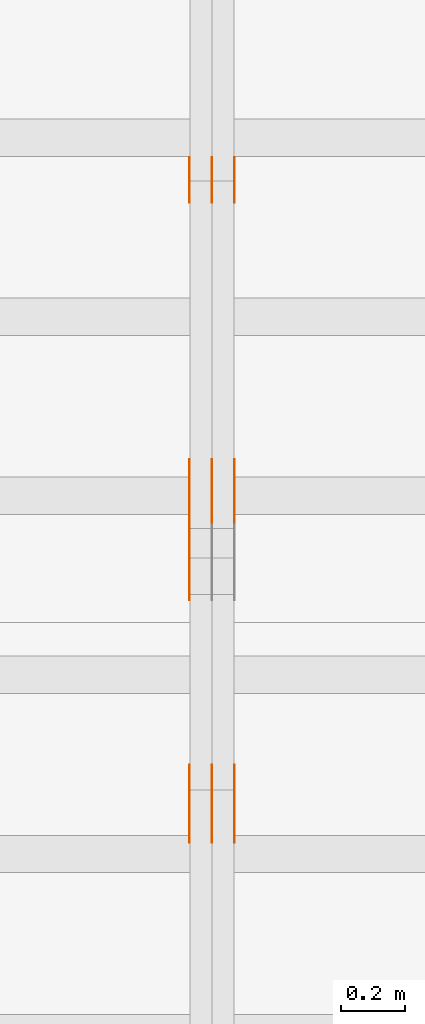
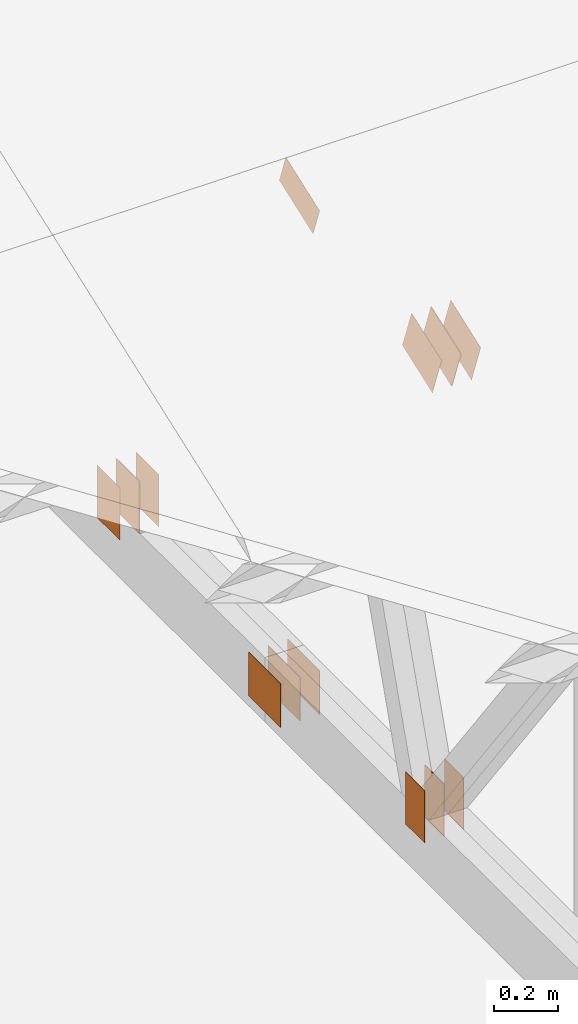
# One storey, part 75 of 189: 17 proxies.
"""IFC2X3 building model written with IfcOpenShell, lengths in millimetres."""

from ifc_helpers import new_model, entity, si_unit, converted_unit, derived_unit, direction, frame, frame_2d, origin, origin_2d_with_axis, place, context, subcontext, project, spatial, polyline, rectangle, outline, extrude, source, transform, mapped, material, type_object, type_shapes, element, save


model = new_model("IFC2X3")

# Units and contexts
model_context = context("Model", 3, precision=0.01, world=origin(), true_north=direction((6.12303176911189e-17, 1.0)))
body_context = subcontext(model_context, "Body", "Model", "MODEL_VIEW")
ifc_project = project(units=[si_unit("LENGTHUNIT", "METRE", prefix="MILLI"), si_unit("AREAUNIT", "SQUARE_METRE"), si_unit("VOLUMEUNIT", "CUBIC_METRE"), converted_unit("PLANEANGLEUNIT", "DEGREE", entity("IfcRatioMeasure", 0.0174532925199433), si_unit("PLANEANGLEUNIT", "RADIAN"), dimensions=[0, 0, 0, 0, 0, 0, 0]), si_unit("MASSUNIT", "GRAM", prefix="KILO"), derived_unit("MASSDENSITYUNIT", [(si_unit("MASSUNIT", "GRAM", prefix="KILO"), 1), (si_unit("LENGTHUNIT", "METRE"), -3)]), si_unit("TIMEUNIT", "SECOND"), si_unit("FREQUENCYUNIT", "HERTZ"), si_unit("THERMODYNAMICTEMPERATUREUNIT", "DEGREE_CELSIUS"), derived_unit("THERMALTRANSMITTANCEUNIT", [(si_unit("MASSUNIT", "GRAM", prefix="KILO"), 1), (si_unit("THERMODYNAMICTEMPERATUREUNIT", "KELVIN"), -1), (si_unit("TIMEUNIT", "SECOND"), -3)]), derived_unit("VOLUMETRICFLOWRATEUNIT", [(si_unit("LENGTHUNIT", "METRE"), 3), (si_unit("TIMEUNIT", "SECOND"), -1)]), si_unit("ELECTRICCURRENTUNIT", "AMPERE"), si_unit("ELECTRICVOLTAGEUNIT", "VOLT"), si_unit("POWERUNIT", "WATT"), si_unit("FORCEUNIT", "NEWTON"), si_unit("ILLUMINANCEUNIT", "LUX"), si_unit("LUMINOUSFLUXUNIT", "LUMEN"), si_unit("LUMINOUSINTENSITYUNIT", "CANDELA"), derived_unit("USERDEFINED", [(si_unit("MASSUNIT", "GRAM", prefix="KILO"), -1), (si_unit("LENGTHUNIT", "METRE"), -2), (si_unit("TIMEUNIT", "SECOND"), 3), (si_unit("LUMINOUSFLUXUNIT", "LUMEN"), 1)]), derived_unit("LINEARVELOCITYUNIT", [(si_unit("LENGTHUNIT", "METRE"), 1), (si_unit("TIMEUNIT", "SECOND"), -1)]), si_unit("PRESSUREUNIT", "PASCAL"), derived_unit("USERDEFINED", [(si_unit("LENGTHUNIT", "METRE"), -2), (si_unit("MASSUNIT", "GRAM", prefix="KILO"), 1), (si_unit("TIMEUNIT", "SECOND"), -2)])], contexts=[model_context])

# Site, building, storey
site_placement = place(None, origin())
site = spatial("IfcSite", under=ifc_project, at=site_placement, CompositionType="ELEMENT")
building_placement = place(site_placement, origin())
building = spatial("IfcBuilding", under=site, at=building_placement, CompositionType="ELEMENT")
storey_placement = place(building_placement, origin())
storey = spatial("IfcBuildingStorey", under=building, at=storey_placement, Name="Default", CompositionType="ELEMENT", Elevation=0.0)

# Proxies
ifc_material_1 = material(Name="IfcSurfaceStyle #79002")
building_element_proxy_type_1 = type_object("IfcBuildingElementProxyType", PredefinedType="NOTDEFINED", material=ifc_material_1)
shared_shape_1 = source(origin(), body_context, "Body", "SweptSolid", [
    extrude(rectangle(XDim=200.0, YDim=144.0, at=frame_2d((1.4210854715202e-14, 0.0), x_axis=(1.0, 0.0))), frame((100.0, 72.0, 0.0), z_axis=(0.0, 0.0, 1.0), x_axis=(-1.0, 0.0, 0.0)), (0.0, 0.0, 1.0), 1.3),
])
type_shapes(building_element_proxy_type_1, [shared_shape_1])
proxy_1_placement = place(building_placement, frame((12301.3, 6668.833984375, 145.0), z_axis=(-1.0, 0.0, 0.0), x_axis=(0.0, 0.0, 1.0)))
element("IfcBuildingElementProxy", 1, at=proxy_1_placement, inside=storey, type_object=building_element_proxy_type_1, material=ifc_material_1, context=body_context, shape_type="MappedRepresentation", body=[
    mapped(shared_shape_1, transform((0.0, 0.0, 0.0), scale=1.0)),
])
ifc_material_2 = material(Name="IfcSurfaceStyle #78945")
building_element_proxy_type_2 = type_object("IfcBuildingElementProxyType", PredefinedType="NOTDEFINED", material=ifc_material_2)
shared_shape_2 = source(origin(), body_context, "Body", "SweptSolid", [
    extrude(rectangle(XDim=200.0, YDim=144.0, at=frame_2d((1.4210854715202e-14, 0.0), x_axis=(1.0, 0.0))), frame((100.0, 72.0, 0.0), z_axis=(0.0, 0.0, 1.0), x_axis=(-1.0, 0.0, 0.0)), (0.0, 0.0, 1.0), 1.29999999999998),
])
type_shapes(building_element_proxy_type_2, [shared_shape_2])
proxy_2_placement = place(building_placement, frame((12230.0, 6668.833984375, 145.0), z_axis=(-1.0, 0.0, 0.0), x_axis=(0.0, 0.0, 1.0)))
element("IfcBuildingElementProxy", 2, at=proxy_2_placement, inside=storey, type_object=building_element_proxy_type_2, material=ifc_material_2, context=body_context, shape_type="MappedRepresentation", body=[
    mapped(shared_shape_2, transform((0.0, 0.0, 0.0), scale=1.0)),
])
ifc_material_3 = material(Name="IfcSurfaceStyle #78888")
building_element_proxy_type_3 = type_object("IfcBuildingElementProxyType", PredefinedType="NOTDEFINED", material=ifc_material_3)
shared_shape_3 = source(origin(), body_context, "Body", "SweptSolid", [
    extrude(rectangle(XDim=200.0, YDim=144.0, at=frame_2d((1.4210854715202e-14, 0.0), x_axis=(1.0, 0.0))), frame((100.0, 72.0, 0.0), z_axis=(0.0, 0.0, 1.0), x_axis=(-1.0, 0.0, 0.0)), (0.0, 0.0, 1.0), 1.29999999999998),
])
type_shapes(building_element_proxy_type_3, [shared_shape_3])
proxy_3_placement = place(building_placement, frame((12231.3, 6668.833984375, 145.0), z_axis=(-1.0, 0.0, 0.0), x_axis=(0.0, 0.0, 1.0)))
element("IfcBuildingElementProxy", 3, at=proxy_3_placement, inside=storey, type_object=building_element_proxy_type_3, material=ifc_material_3, context=body_context, shape_type="MappedRepresentation", body=[
    mapped(shared_shape_3, transform((0.0, 0.0, 0.0), scale=1.0)),
])
ifc_material_4 = material(Name="IfcSurfaceStyle #78831")
building_element_proxy_type_4 = type_object("IfcBuildingElementProxyType", PredefinedType="NOTDEFINED", material=ifc_material_4)
shared_shape_4 = source(origin(), body_context, "Body", "SweptSolid", [
    extrude(rectangle(XDim=200.0, YDim=144.0, at=frame_2d((1.4210854715202e-14, 0.0), x_axis=(1.0, 0.0))), frame((100.0, 72.0, 0.0), z_axis=(0.0, 0.0, 1.0), x_axis=(-1.0, 0.0, 0.0)), (0.0, 0.0, 1.0), 1.29999999999999),
])
type_shapes(building_element_proxy_type_4, [shared_shape_4])
proxy_4_placement = place(building_placement, frame((12160.0, 6668.833984375, 145.0), z_axis=(-1.0, 0.0, 0.0), x_axis=(0.0, 0.0, 1.0)))
element("IfcBuildingElementProxy", 4, at=proxy_4_placement, inside=storey, type_object=building_element_proxy_type_4, material=ifc_material_4, context=body_context, shape_type="MappedRepresentation", body=[
    mapped(shared_shape_4, transform((0.0, 0.0, 0.0), scale=1.0)),
])
ifc_material_5 = material(Name="IfcSurfaceStyle #78774")
building_element_proxy_type_5 = type_object("IfcBuildingElementProxyType", PredefinedType="NOTDEFINED", material=ifc_material_5)
shared_shape_5 = source(origin(), body_context, "Body", "SweptSolid", [
    extrude(rectangle(XDim=200.0, YDim=168.0, at=origin_2d_with_axis()), frame((100.0, 84.0, 0.0), z_axis=(0.0, 0.0, 1.0), x_axis=(-1.0, 0.0, 0.0)), (0.0, 0.0, 1.0), 1.3),
])
type_shapes(building_element_proxy_type_5, [shared_shape_5])
proxy_5_placement = place(building_placement, frame((12301.3, 5662.466796875, 206.5), z_axis=(-1.0, 0.0, 0.0), x_axis=(0.0, 1.0, 0.0)))
element("IfcBuildingElementProxy", 5, at=proxy_5_placement, inside=storey, type_object=building_element_proxy_type_5, material=ifc_material_5, context=body_context, shape_type="MappedRepresentation", body=[
    mapped(shared_shape_5, transform((0.0, 0.0, 0.0), scale=1.0)),
])
ifc_material_6 = material(Name="IfcSurfaceStyle #78717")
building_element_proxy_type_6 = type_object("IfcBuildingElementProxyType", PredefinedType="NOTDEFINED", material=ifc_material_6)
shared_shape_6 = source(origin(), body_context, "Body", "SweptSolid", [
    extrude(rectangle(XDim=200.0, YDim=168.0, at=origin_2d_with_axis()), frame((100.0, 84.0, 0.0), z_axis=(0.0, 0.0, 1.0), x_axis=(-1.0, 0.0, 0.0)), (0.0, 0.0, 1.0), 1.29999999999998),
])
type_shapes(building_element_proxy_type_6, [shared_shape_6])
proxy_6_placement = place(building_placement, frame((12230.0, 5662.466796875, 206.5), z_axis=(-1.0, 0.0, 0.0), x_axis=(0.0, 1.0, 0.0)))
element("IfcBuildingElementProxy", 6, at=proxy_6_placement, inside=storey, type_object=building_element_proxy_type_6, material=ifc_material_6, context=body_context, shape_type="MappedRepresentation", body=[
    mapped(shared_shape_6, transform((0.0, 0.0, 0.0), scale=1.0)),
])
ifc_material_7 = material(Name="IfcSurfaceStyle #78660")
building_element_proxy_type_7 = type_object("IfcBuildingElementProxyType", PredefinedType="NOTDEFINED", material=ifc_material_7)
shared_shape_7 = source(origin(), body_context, "Body", "SweptSolid", [
    extrude(rectangle(XDim=200.0, YDim=168.0, at=origin_2d_with_axis()), frame((100.0, 84.0, 0.0), z_axis=(0.0, 0.0, 1.0), x_axis=(-1.0, 0.0, 0.0)), (0.0, 0.0, 1.0), 1.29999999999998),
])
type_shapes(building_element_proxy_type_7, [shared_shape_7])
proxy_7_placement = place(building_placement, frame((12231.3, 5662.466796875, 206.5), z_axis=(-1.0, 0.0, 0.0), x_axis=(0.0, 1.0, 0.0)))
element("IfcBuildingElementProxy", 7, at=proxy_7_placement, inside=storey, type_object=building_element_proxy_type_7, material=ifc_material_7, context=body_context, shape_type="MappedRepresentation", body=[
    mapped(shared_shape_7, transform((0.0, 0.0, 0.0), scale=1.0)),
])
ifc_material_8 = material(Name="IfcSurfaceStyle #78603")
building_element_proxy_type_8 = type_object("IfcBuildingElementProxyType", PredefinedType="NOTDEFINED", material=ifc_material_8)
shared_shape_8 = source(origin(), body_context, "Body", "SweptSolid", [
    extrude(rectangle(XDim=200.0, YDim=168.0, at=origin_2d_with_axis()), frame((100.0, 84.0, 0.0), z_axis=(0.0, 0.0, 1.0), x_axis=(-1.0, 0.0, 0.0)), (0.0, 0.0, 1.0), 1.29999999999999),
])
type_shapes(building_element_proxy_type_8, [shared_shape_8])
proxy_8_placement = place(building_placement, frame((12160.0, 5662.466796875, 206.5), z_axis=(-1.0, 0.0, 0.0), x_axis=(0.0, 1.0, 0.0)))
element("IfcBuildingElementProxy", 8, at=proxy_8_placement, inside=storey, type_object=building_element_proxy_type_8, material=ifc_material_8, context=body_context, shape_type="MappedRepresentation", body=[
    mapped(shared_shape_8, transform((0.0, 0.0, 0.0), scale=1.0)),
])
ifc_material_9 = material(Name="IfcSurfaceStyle #74955")
building_element_proxy_type_9 = type_object("IfcBuildingElementProxyType", PredefinedType="NOTDEFINED", material=ifc_material_9)
shared_shape_9 = source(origin(), body_context, "Body", "SweptSolid", [
    extrude(outline(polyline([(-112.500654374667, -59.9999021691247), (112.500117969231, -59.9999021691247), (112.500612624162, 59.9999021691247), (-112.500076218726, 59.9999021691247), (-112.500654374667, -59.9999021691247)])), frame((112.500612624162, 60.0003514046321, 0.0), z_axis=(0.0, 0.0, 1.0), x_axis=(-1.0, 0.0, 0.0)), (0.0, 0.0, 1.0), 1.29999999999999),
])
type_shapes(building_element_proxy_type_9, [shared_shape_9])
proxy_9_placement = place(building_placement, frame((12160.0, 5418.0703125, 2162.37353515625), z_axis=(-1.0, 0.0, 0.0), x_axis=(0.0, 0.939692620785908, 0.342020143325669)))
element("IfcBuildingElementProxy", 9, at=proxy_9_placement, inside=storey, type_object=building_element_proxy_type_9, material=ifc_material_9, context=body_context, shape_type="MappedRepresentation", body=[
    mapped(shared_shape_9, transform((0.0, 0.0, 0.0), scale=1.0)),
])
ifc_material_10 = material(Name="IfcSurfaceStyle #74442")
building_element_proxy_type_10 = type_object("IfcBuildingElementProxyType", PredefinedType="NOTDEFINED", material=ifc_material_10)
shared_shape_10 = source(origin(), body_context, "Body", "SweptSolid", [
    extrude(rectangle(XDim=200.0, YDim=120.0, at=origin_2d_with_axis()), frame((100.0, 60.0, 0.0), z_axis=(0.0, 0.0, 1.0), x_axis=(-1.0, 0.0, 0.0)), (0.0, 0.0, 1.0), 1.3),
])
type_shapes(building_element_proxy_type_10, [shared_shape_10])
proxy_10_placement = place(building_placement, frame((12301.3, 4760.65625, 145.0), z_axis=(-1.0, 0.0, 0.0), x_axis=(0.0, 0.0, 1.0)))
element("IfcBuildingElementProxy", 10, at=proxy_10_placement, inside=storey, type_object=building_element_proxy_type_10, material=ifc_material_10, context=body_context, shape_type="MappedRepresentation", body=[
    mapped(shared_shape_10, transform((0.0, 0.0, 0.0), scale=1.0)),
])
ifc_material_11 = material(Name="IfcSurfaceStyle #74385")
building_element_proxy_type_11 = type_object("IfcBuildingElementProxyType", PredefinedType="NOTDEFINED", material=ifc_material_11)
shared_shape_11 = source(origin(), body_context, "Body", "SweptSolid", [
    extrude(rectangle(XDim=200.0, YDim=120.0, at=origin_2d_with_axis()), frame((100.0, 60.0, 0.0), z_axis=(0.0, 0.0, 1.0), x_axis=(-1.0, 0.0, 0.0)), (0.0, 0.0, 1.0), 1.29999999999998),
])
type_shapes(building_element_proxy_type_11, [shared_shape_11])
proxy_11_placement = place(building_placement, frame((12230.0, 4760.65625, 145.0), z_axis=(-1.0, 0.0, 0.0), x_axis=(0.0, 0.0, 1.0)))
element("IfcBuildingElementProxy", 11, at=proxy_11_placement, inside=storey, type_object=building_element_proxy_type_11, material=ifc_material_11, context=body_context, shape_type="MappedRepresentation", body=[
    mapped(shared_shape_11, transform((0.0, 0.0, 0.0), scale=1.0)),
])
ifc_material_12 = material(Name="IfcSurfaceStyle #74328")
building_element_proxy_type_12 = type_object("IfcBuildingElementProxyType", PredefinedType="NOTDEFINED", material=ifc_material_12)
shared_shape_12 = source(origin(), body_context, "Body", "SweptSolid", [
    extrude(rectangle(XDim=200.0, YDim=120.0, at=origin_2d_with_axis()), frame((100.0, 60.0, 0.0), z_axis=(0.0, 0.0, 1.0), x_axis=(-1.0, 0.0, 0.0)), (0.0, 0.0, 1.0), 1.29999999999998),
])
type_shapes(building_element_proxy_type_12, [shared_shape_12])
proxy_12_placement = place(building_placement, frame((12231.3, 4760.65625, 145.0), z_axis=(-1.0, 0.0, 0.0), x_axis=(0.0, 0.0, 1.0)))
element("IfcBuildingElementProxy", 12, at=proxy_12_placement, inside=storey, type_object=building_element_proxy_type_12, material=ifc_material_12, context=body_context, shape_type="MappedRepresentation", body=[
    mapped(shared_shape_12, transform((0.0, 0.0, 0.0), scale=1.0)),
])
ifc_material_13 = material(Name="IfcSurfaceStyle #74271")
building_element_proxy_type_13 = type_object("IfcBuildingElementProxyType", PredefinedType="NOTDEFINED", material=ifc_material_13)
shared_shape_13 = source(origin(), body_context, "Body", "SweptSolid", [
    extrude(rectangle(XDim=200.0, YDim=120.0, at=origin_2d_with_axis()), frame((100.0, 60.0, 0.0), z_axis=(0.0, 0.0, 1.0), x_axis=(-1.0, 0.0, 0.0)), (0.0, 0.0, 1.0), 1.29999999999999),
])
type_shapes(building_element_proxy_type_13, [shared_shape_13])
proxy_13_placement = place(building_placement, frame((12160.0, 4760.65625, 145.0), z_axis=(-1.0, 0.0, 0.0), x_axis=(0.0, 0.0, 1.0)))
element("IfcBuildingElementProxy", 13, at=proxy_13_placement, inside=storey, type_object=building_element_proxy_type_13, material=ifc_material_13, context=body_context, shape_type="MappedRepresentation", body=[
    mapped(shared_shape_13, transform((0.0, 0.0, 0.0), scale=1.0)),
])
ifc_material_14 = material(Name="IfcSurfaceStyle #69546")
building_element_proxy_type_14 = type_object("IfcBuildingElementProxyType", PredefinedType="NOTDEFINED", material=ifc_material_14)
shared_shape_14 = source(origin(), body_context, "Body", "SweptSolid", [
    extrude(outline(polyline([(-99.9993269270171, -84.0000832532405), (99.9997189122032, -84.0000832532405), (99.9992851765118, 84.0000832532405), (-99.999677161698, 84.0000832532405), (-99.9993269270171, -84.0000832532405)])), frame((99.9999283659736, 84.0000832532405, 0.0), z_axis=(0.0, 0.0, 1.0), x_axis=(-1.0, 0.0, 0.0)), (0.0, 0.0, 1.0), 1.3),
])
type_shapes(building_element_proxy_type_14, [shared_shape_14])
proxy_14_placement = place(building_placement, frame((12301.3, 4654.06379965055, 2052.96988554922), z_axis=(-1.0, 0.0, 0.0), x_axis=(0.0, 0.939692620785908, 0.342020143325669)))
element("IfcBuildingElementProxy", 14, at=proxy_14_placement, inside=storey, type_object=building_element_proxy_type_14, material=ifc_material_14, context=body_context, shape_type="MappedRepresentation", body=[
    mapped(shared_shape_14, transform((0.0, 0.0, 0.0), scale=1.0)),
])
ifc_material_15 = material(Name="IfcSurfaceStyle #69489")
building_element_proxy_type_15 = type_object("IfcBuildingElementProxyType", PredefinedType="NOTDEFINED", material=ifc_material_15)
shared_shape_15 = source(origin(), body_context, "Body", "SweptSolid", [
    extrude(outline(polyline([(-99.9993269270171, -84.0000832532405), (99.9997189122032, -84.0000832532405), (99.9992851765118, 84.0000832532405), (-99.999677161698, 84.0000832532405), (-99.9993269270171, -84.0000832532405)])), frame((99.9999283659736, 84.0000832532405, 0.0), z_axis=(0.0, 0.0, 1.0), x_axis=(-1.0, 0.0, 0.0)), (0.0, 0.0, 1.0), 1.29999999999998),
])
type_shapes(building_element_proxy_type_15, [shared_shape_15])
proxy_15_placement = place(building_placement, frame((12230.0, 4654.06379965055, 2052.96988554922), z_axis=(-1.0, 0.0, 0.0), x_axis=(0.0, 0.939692620785908, 0.342020143325669)))
element("IfcBuildingElementProxy", 15, at=proxy_15_placement, inside=storey, type_object=building_element_proxy_type_15, material=ifc_material_15, context=body_context, shape_type="MappedRepresentation", body=[
    mapped(shared_shape_15, transform((0.0, 0.0, 0.0), scale=1.0)),
])
ifc_material_16 = material(Name="IfcSurfaceStyle #69432")
building_element_proxy_type_16 = type_object("IfcBuildingElementProxyType", PredefinedType="NOTDEFINED", material=ifc_material_16)
shared_shape_16 = source(origin(), body_context, "Body", "SweptSolid", [
    extrude(outline(polyline([(-99.9993269270171, -84.0000832532405), (99.9997189122032, -84.0000832532405), (99.9992851765118, 84.0000832532405), (-99.999677161698, 84.0000832532405), (-99.9993269270171, -84.0000832532405)])), frame((99.9999283659736, 84.0000832532405, 0.0), z_axis=(0.0, 0.0, 1.0), x_axis=(-1.0, 0.0, 0.0)), (0.0, 0.0, 1.0), 1.29999999999998),
])
type_shapes(building_element_proxy_type_16, [shared_shape_16])
proxy_16_placement = place(building_placement, frame((12231.3, 4654.06379965055, 2052.96988554922), z_axis=(-1.0, 0.0, 0.0), x_axis=(0.0, 0.939692620785908, 0.342020143325669)))
element("IfcBuildingElementProxy", 16, at=proxy_16_placement, inside=storey, type_object=building_element_proxy_type_16, material=ifc_material_16, context=body_context, shape_type="MappedRepresentation", body=[
    mapped(shared_shape_16, transform((0.0, 0.0, 0.0), scale=1.0)),
])
ifc_material_17 = material(Name="IfcSurfaceStyle #69375")
building_element_proxy_type_17 = type_object("IfcBuildingElementProxyType", PredefinedType="NOTDEFINED", material=ifc_material_17)
shared_shape_17 = source(origin(), body_context, "Body", "SweptSolid", [
    extrude(outline(polyline([(-99.9993269270171, -84.0000832532405), (99.9997189122032, -84.0000832532405), (99.9992851765118, 84.0000832532405), (-99.999677161698, 84.0000832532405), (-99.9993269270171, -84.0000832532405)])), frame((99.9999283659736, 84.0000832532405, 0.0), z_axis=(0.0, 0.0, 1.0), x_axis=(-1.0, 0.0, 0.0)), (0.0, 0.0, 1.0), 1.29999999999999),
])
type_shapes(building_element_proxy_type_17, [shared_shape_17])
proxy_17_placement = place(building_placement, frame((12160.0, 4654.06379965055, 2052.96988554922), z_axis=(-1.0, 0.0, 0.0), x_axis=(0.0, 0.939692620785908, 0.342020143325669)))
element("IfcBuildingElementProxy", 17, at=proxy_17_placement, inside=storey, type_object=building_element_proxy_type_17, material=ifc_material_17, context=body_context, shape_type="MappedRepresentation", body=[
    mapped(shared_shape_17, transform((0.0, 0.0, 0.0), scale=1.0)),
])

save(model, "model.ifc")
